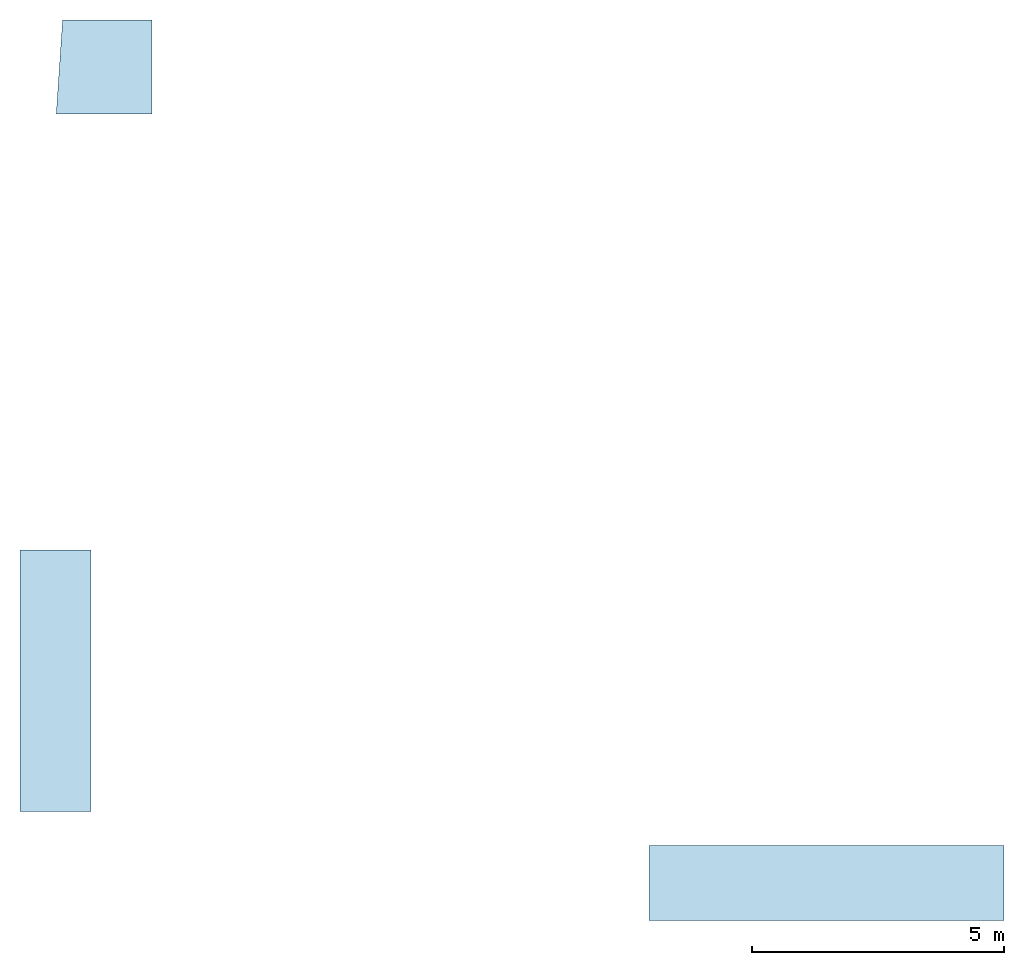
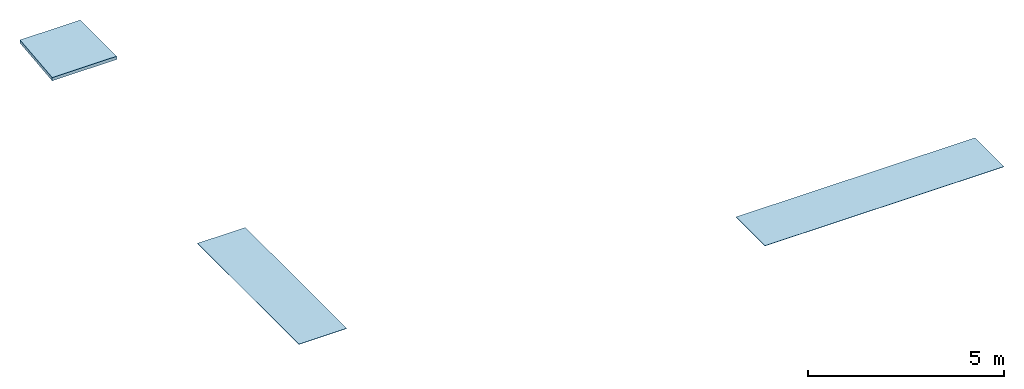
# One storey: 3 slabs.
"""IFC4X3_ADD2 building model written with IfcOpenShell, lengths in metres."""

from ifc_helpers import new_model, entity, si_unit, converted_unit, frame, origin_with_axes, origin_2d_with_axis, place, context, subcontext, project, spatial, line, indexed_curve, outline, extrude, material, layer, layer_set, layer_usage, type_object, element, save


model = new_model("IFC4X3_ADD2")

# Units and contexts
model_context = context("Model", 3, precision=1e-05, world=origin_with_axes())
plan_context = context("Plan", 2, precision=1e-05, world=origin_2d_with_axis())
body_context = subcontext(model_context, "Body", "Model", "MODEL_VIEW")
ifc_project = project(units=[si_unit("VOLUMEUNIT", "CUBIC_METRE"), si_unit("LENGTHUNIT", "METRE"), converted_unit("PLANEANGLEUNIT", "degree", entity("IfcReal", 0.0174532925199433), si_unit("PLANEANGLEUNIT", "RADIAN"), dimensions=[0, 0, 0, 0, 0, 0, 0]), si_unit("AREAUNIT", "SQUARE_METRE")], contexts=[model_context, plan_context])

# Site, building, storey
site_placement = place(None, origin_with_axes())
site = spatial("IfcSite", under=ifc_project, at=site_placement)
building_placement = place(site_placement, origin_with_axes())
building = spatial("IfcBuilding", under=site, at=building_placement, Name="Building")
storey_placement = place(building_placement, frame((0.0, 0.0, 2.54999995231628), z_axis=(0.0, 0.0, 1.0), x_axis=(1.0, 0.0, 0.0)))
storey = spatial("IfcBuildingStorey", under=building, at=storey_placement, Name="GF Lintel")

# Slabs
ifc_material_1 = material(Name="Concrete")
ifc_layer_1 = layer(ifc_material_1, 0.100000001490116)
ifc_layer_set_1 = layer_set([ifc_layer_1])
ifc_layer_usage_1 = layer_usage(ifc_layer_set_1, "AXIS3", "POSITIVE", 0.0)
slab_type_1 = type_object("IfcSlabType", Name="Concrete 100mm", PredefinedType="FLOOR", material=ifc_layer_set_1)
slab_1_placement = place(storey_placement, frame((3.45033311843872, 26.4772186279297, -0.0499999523162842), z_axis=(0.0, 0.0, 1.0), x_axis=(1.0, 0.0, 0.0)))
element("IfcSlab", 1, at=slab_1_placement, inside=storey, type_object=slab_type_1, material=ifc_layer_usage_1, Name="Slab", context=body_context, shape_type="SweptSolid", body=[
    extrude(outline(indexed_curve([(0.544827938079834, 4.75924301147461), (2.31760883331299, 4.75924301147461), (2.31760883331299, 2.89924240112305), (0.419144153594971, 2.89924621582031)], segments=[line(4, 1), line(1, 2), line(2, 3), line(3, 4)], self_intersect=False)), None, (0.0, 0.0, 1.0), 0.100000001490116),
])
ifc_material_2 = material(Name="Glass")
ifc_layer_2 = layer(ifc_material_2, 0.00999999977648258)
ifc_layer_set_2 = layer_set([ifc_layer_2])
ifc_layer_usage_2 = layer_usage(ifc_layer_set_2, "AXIS3", "POSITIVE", 0.0)
slab_type_2 = type_object("IfcSlabType", Name="Glass 4mm", PredefinedType="FLOOR", material=ifc_layer_set_2)
slab_2_placement = place(storey_placement, frame((2.70026230812073, 15.5573253631592, 0.378779411315918), z_axis=(0.0, 0.0, 1.0), x_axis=(1.0, 0.0, 0.0)))
element("IfcSlab", 2, at=slab_2_placement, inside=storey, type_object=slab_type_2, material=ifc_layer_usage_2, Name="Slab", context=body_context, shape_type="SweptSolid", body=[
    extrude(outline(indexed_curve([(1.85951519012451, 5.17584419250488), (1.85951519012451, 0.0), (0.451248168945312, 0.0), (0.451248168945312, 5.17584419250488)], segments=[line(3, 2), line(2, 1), line(1, 4), line(4, 3)], self_intersect=False)), None, (0.0, 0.0, 1.0), 0.00999999977648258),
])
ifc_layer_usage_3 = layer_usage(ifc_layer_set_2, "AXIS3", "POSITIVE", 0.0)
slab_3_placement = place(storey_placement, frame((22.64697265625, 13.398157119751, 0.387302160263062), z_axis=(0.0, 0.0, 1.0), x_axis=(-4.37113882867379e-08, 0.999999999999999, 0.0)))
element("IfcSlab", 3, at=slab_3_placement, inside=storey, type_object=slab_type_2, material=ifc_layer_usage_3, Name="Slab", context=body_context, shape_type="SweptSolid", body=[
    extrude(outline(indexed_curve([(1.47892868518829, 7.03120517730713), (1.478928565979, 1.66359690467743e-08), (0.0, 0.0), (8.11004028378193e-08, 7.03120517730713)], segments=[line(3, 2), line(2, 1), line(1, 4), line(4, 3)], self_intersect=False)), None, (0.0, 0.0, 1.0), 0.00999999977648258),
])

save(model, "model.ifc")
